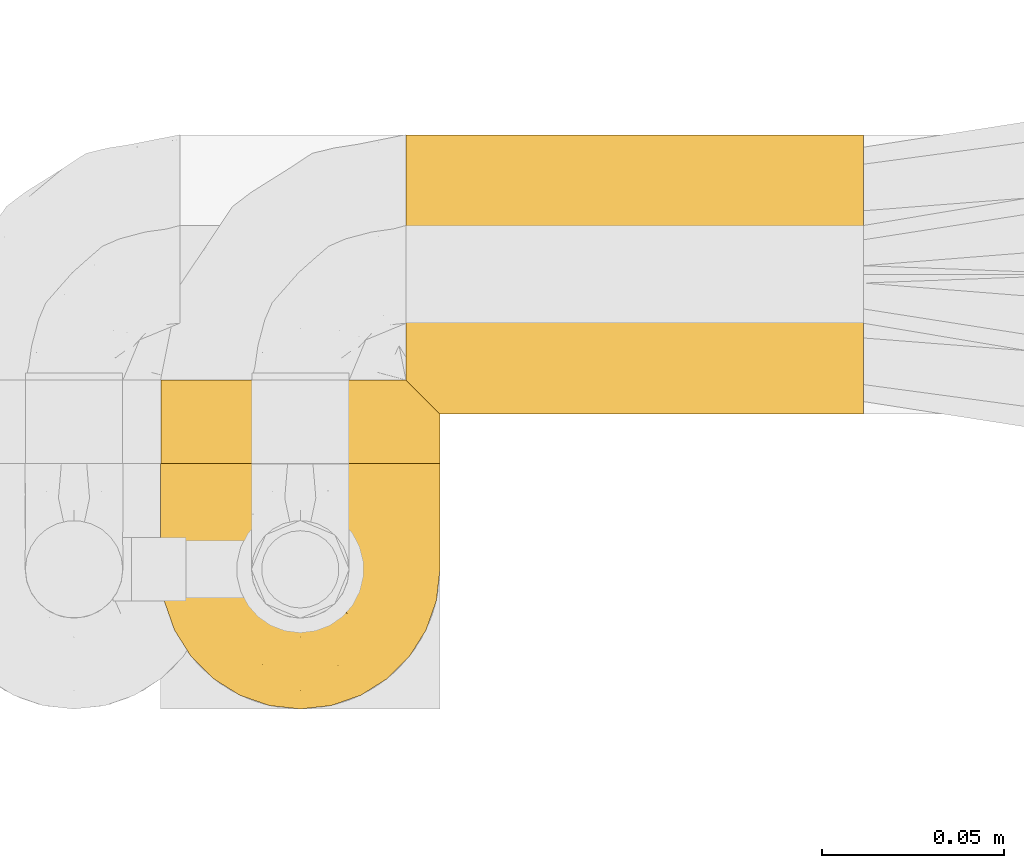
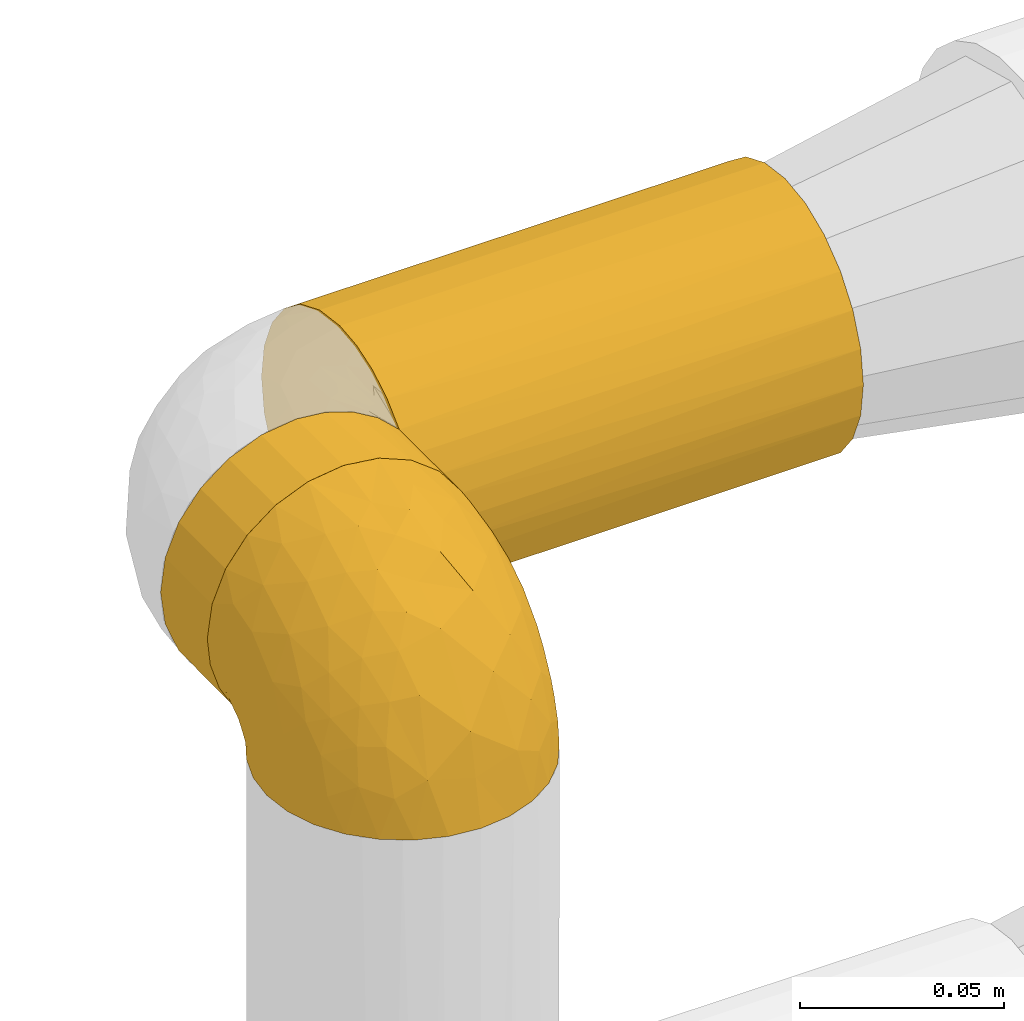
# One storey, part 335 of 827: 3 coverings.
"""IFC2X3 building model written with IfcOpenShell, lengths in millimetres."""

from ifc_helpers import new_model, entity, si_unit, converted_unit, derived_unit, direction, frame, origin, place, context, subcontext, project, spatial, faceted_brep, element, save


model = new_model("IFC2X3")

# Units and contexts
model_context = context("Model", 3, precision=0.01, world=origin(), true_north=direction((6.12303176911189e-17, 1.0)))
body_context = subcontext(model_context, "Body", "Model", "MODEL_VIEW")
ifc_project = project(units=[si_unit("LENGTHUNIT", "METRE", prefix="MILLI"), si_unit("AREAUNIT", "SQUARE_METRE"), si_unit("VOLUMEUNIT", "CUBIC_METRE"), converted_unit("PLANEANGLEUNIT", "DEGREE", entity("IfcRatioMeasure", 0.0174532925199433), si_unit("PLANEANGLEUNIT", "RADIAN"), dimensions=[0, 0, 0, 0, 0, 0, 0]), si_unit("MASSUNIT", "GRAM", prefix="KILO"), derived_unit("MASSDENSITYUNIT", [(si_unit("MASSUNIT", "GRAM", prefix="KILO"), 1), (si_unit("LENGTHUNIT", "METRE"), -3)]), derived_unit("MOMENTOFINERTIAUNIT", [(si_unit("LENGTHUNIT", "METRE"), 4)]), si_unit("TIMEUNIT", "SECOND"), si_unit("FREQUENCYUNIT", "HERTZ"), si_unit("THERMODYNAMICTEMPERATUREUNIT", "DEGREE_CELSIUS"), derived_unit("THERMALTRANSMITTANCEUNIT", [(si_unit("MASSUNIT", "GRAM", prefix="KILO"), 1), (si_unit("THERMODYNAMICTEMPERATUREUNIT", "KELVIN"), -1), (si_unit("TIMEUNIT", "SECOND"), -3)]), derived_unit("VOLUMETRICFLOWRATEUNIT", [(si_unit("LENGTHUNIT", "METRE"), 3), (si_unit("TIMEUNIT", "SECOND"), -1)]), derived_unit("MASSFLOWRATEUNIT", [(si_unit("MASSUNIT", "GRAM", prefix="KILO"), 1), (si_unit("TIMEUNIT", "SECOND"), -1)]), derived_unit("ROTATIONALFREQUENCYUNIT", [(si_unit("TIMEUNIT", "SECOND"), -1)]), si_unit("ELECTRICCURRENTUNIT", "AMPERE"), si_unit("ELECTRICVOLTAGEUNIT", "VOLT"), si_unit("POWERUNIT", "WATT"), si_unit("FORCEUNIT", "NEWTON", prefix="KILO"), si_unit("ILLUMINANCEUNIT", "LUX"), si_unit("LUMINOUSFLUXUNIT", "LUMEN"), si_unit("LUMINOUSINTENSITYUNIT", "CANDELA"), derived_unit("USERDEFINED", [(si_unit("MASSUNIT", "GRAM", prefix="KILO"), -1), (si_unit("LENGTHUNIT", "METRE"), -2), (si_unit("TIMEUNIT", "SECOND"), 3), (si_unit("LUMINOUSFLUXUNIT", "LUMEN"), 1)]), derived_unit("LINEARVELOCITYUNIT", [(si_unit("LENGTHUNIT", "METRE"), 1), (si_unit("TIMEUNIT", "SECOND"), -1)]), si_unit("PRESSUREUNIT", "PASCAL"), derived_unit("USERDEFINED", [(si_unit("LENGTHUNIT", "METRE"), -2), (si_unit("MASSUNIT", "GRAM", prefix="KILO"), 1), (si_unit("TIMEUNIT", "SECOND"), -2)]), derived_unit("LINEARFORCEUNIT", [(si_unit("MASSUNIT", "GRAM", prefix="KILO"), 1), (si_unit("LENGTHUNIT", "METRE"), 1), (si_unit("TIMEUNIT", "SECOND"), -2), (si_unit("LENGTHUNIT", "METRE"), -1)]), derived_unit("PLANARFORCEUNIT", [(si_unit("MASSUNIT", "GRAM", prefix="KILO"), 1), (si_unit("LENGTHUNIT", "METRE"), 1), (si_unit("TIMEUNIT", "SECOND"), -2), (si_unit("LENGTHUNIT", "METRE"), -2)])], contexts=[model_context])

# Site, building, storey
site_placement = place(None, origin())
site = spatial("IfcSite", under=ifc_project, at=site_placement, CompositionType="ELEMENT")
building_placement = place(site_placement, origin())
building = spatial("IfcBuilding", under=site, at=building_placement, CompositionType="ELEMENT")
storey_placement = place(building_placement, frame((0.0, 0.0, 28200.0)))
storey = spatial("IfcBuildingStorey", under=building, at=storey_placement, Name="08", CompositionType="ELEMENT", Elevation=28200.0)

# Coverings
covering_1_placement = place(storey_placement, frame((35083.54, 19454.61, 1910.0)))
element("IfcCovering", 1, at=covering_1_placement, inside=storey, Name=":ADSK_", ObjectType=":ADSK_", PredefinedType="INSULATION", context=body_context, shape_type="Brep", body=[
    faceted_brep([(1.6, 23.98, 5.09), (1.6, 16.91, 9.31), (1.6, 10.9, 14.94), (1.6, 10.9, 65.05), (1.6, 16.91, 70.68), (1.6, 23.98, 74.9), (1.6, 31.79, 77.51), (1.6, 40.0, 78.4), (1.6, 49.93, 77.09), (1.6, 59.2, 73.25), (1.6, 67.15, 67.15), (1.6, 73.25, 59.2), (1.6, 77.09, 49.93), (1.6, 78.4, 40.0), (1.6, 77.09, 30.06), (1.6, 73.25, 20.8), (1.6, 67.15, 12.84), (1.6, 59.2, 6.74), (1.6, 49.93, 2.9), (1.6, 40.0, 1.6), (1.6, 31.79, 2.48), (127.48, 1.6, 40.0), (127.48, 2.9, 30.06), (127.48, 6.74, 20.8), (127.48, 12.84, 12.84), (127.48, 20.8, 6.74), (127.48, 30.06, 2.9), (127.48, 40.0, 1.6), (127.48, 49.93, 2.9), (127.48, 59.2, 6.74), (127.48, 67.15, 12.84), (127.48, 73.25, 20.8), (127.48, 77.09, 30.06), (127.48, 78.4, 40.0), (127.48, 77.09, 49.93), (127.48, 73.25, 59.2), (127.48, 67.15, 67.15), (127.48, 59.2, 73.25), (127.48, 49.93, 77.09), (127.48, 40.0, 78.4), (127.48, 30.06, 77.09), (127.48, 20.8, 73.25), (127.48, 12.84, 67.15), (127.48, 6.74, 59.2), (127.48, 2.9, 49.93), (8.5, 4.0, 26.63), (10.29, 2.2, 33.21), (10.9, 1.6, 40.0), (5.57, 6.92, 20.48), (10.29, 2.2, 46.78), (8.5, 4.0, 53.36), (5.57, 6.92, 59.51)], [[[0, 1, 2, 3, 4, 5, 6, 7, 8, 9, 10, 11, 12, 13, 14, 15, 16, 17, 18, 19, 20]], [[21, 22, 23, 24, 25, 26, 27, 28, 29, 30, 31, 32, 33, 34, 35, 36, 37, 38, 39, 40, 41, 42, 43, 44]], [[32, 31, 15, 14]], [[33, 32, 14, 13]], [[31, 30, 16, 15]], [[18, 17, 29, 28]], [[19, 18, 28, 27]], [[30, 29, 17, 16]], [[20, 27, 26]], [[0, 26, 25]], [[1, 25, 24]], [[19, 27, 20]], [[20, 26, 0]], [[25, 1, 0]], [[24, 2, 1]], [[45, 23, 22]], [[22, 21, 46]], [[47, 46, 21]], [[48, 2, 23]], [[46, 45, 22]], [[48, 23, 45]], [[23, 2, 24]], [[49, 47, 21]], [[49, 21, 44]], [[50, 44, 43]], [[50, 49, 44]], [[3, 51, 43]], [[50, 43, 51]], [[43, 42, 3]], [[4, 42, 41]], [[5, 41, 40]], [[6, 40, 39]], [[4, 41, 5]], [[5, 40, 6]], [[39, 7, 6]], [[42, 4, 3]], [[8, 7, 39, 38]], [[9, 8, 38, 37]], [[37, 36, 10, 9]], [[12, 11, 35, 34]], [[13, 12, 34, 33]], [[36, 35, 11, 10]], [[2, 48, 45, 46, 47, 49, 50, 51, 3]]]),
])
covering_2_placement = place(storey_placement, frame((35016.04, 19440.94, 1910.0)))
element("IfcCovering", 2, at=covering_2_placement, inside=storey, Name=":ADSK_", ObjectType=":ADSK_", PredefinedType="INSULATION", context=body_context, shape_type="Brep", body=[
    faceted_brep([(20.8, 24.57, 73.25), (30.06, 24.57, 77.09), (40.0, 24.57, 78.4), (48.2, 24.57, 77.51), (56.01, 24.57, 74.9), (63.08, 24.57, 70.68), (69.1, 24.57, 65.05), (69.1, 24.57, 14.94), (63.08, 24.57, 9.31), (56.01, 24.57, 5.09), (48.2, 24.57, 2.48), (40.0, 24.57, 1.6), (30.06, 24.57, 2.9), (20.8, 24.57, 6.74), (12.84, 24.57, 12.84), (6.74, 24.57, 20.8), (2.9, 24.57, 30.06), (1.6, 24.57, 40.0), (2.9, 24.57, 49.93), (6.74, 24.57, 59.2), (12.84, 24.57, 67.15), (40.0, 1.6, 78.4), (30.06, 1.6, 77.09), (20.8, 1.6, 73.25), (12.84, 1.6, 67.15), (6.74, 1.6, 59.2), (2.9, 1.6, 49.93), (1.6, 1.6, 40.0), (2.48, 1.6, 31.79), (5.09, 1.6, 23.98), (9.31, 1.6, 16.91), (14.94, 1.6, 10.9), (65.05, 1.6, 10.9), (70.68, 1.6, 16.91), (74.9, 1.6, 23.98), (77.51, 1.6, 31.79), (78.4, 1.6, 40.0), (77.09, 1.6, 49.93), (73.25, 1.6, 59.2), (67.15, 1.6, 67.15), (59.2, 1.6, 73.25), (49.93, 1.6, 77.09), (77.79, 15.87, 33.21), (76.0, 17.67, 26.63), (73.07, 20.6, 20.48), (78.4, 15.27, 40.0), (59.51, 5.57, 6.92), (53.36, 8.5, 4.0), (46.78, 10.29, 2.2), (40.0, 10.9, 1.6), (33.21, 10.29, 2.2), (26.63, 8.5, 4.0), (20.48, 5.57, 6.92), (76.0, 17.67, 53.36), (77.79, 15.87, 46.78), (73.07, 20.6, 59.51)], [[[0, 1, 2, 3, 4, 5, 6, 7, 8, 9, 10, 11, 12, 13, 14, 15, 16, 17, 18, 19, 20]], [[21, 22, 23, 24, 25, 26, 27, 28, 29, 30, 31, 32, 33, 34, 35, 36, 37, 38, 39, 40, 41]], [[42, 36, 35]], [[35, 34, 43]], [[33, 44, 34]], [[42, 45, 36]], [[44, 43, 34]], [[7, 44, 33]], [[42, 35, 43]], [[33, 32, 7]], [[32, 46, 8]], [[47, 48, 10]], [[46, 47, 9]], [[8, 46, 9]], [[48, 11, 10]], [[10, 9, 47]], [[11, 48, 49]], [[32, 8, 7]], [[50, 51, 12]], [[13, 52, 14]], [[51, 52, 13]], [[49, 50, 11]], [[11, 50, 12]], [[51, 13, 12]], [[52, 31, 14]], [[15, 30, 29]], [[29, 28, 16]], [[27, 17, 28]], [[14, 30, 15]], [[16, 15, 29]], [[17, 16, 28]], [[30, 14, 31]], [[17, 27, 26, 18]], [[18, 26, 25, 19]], [[19, 25, 24, 20]], [[0, 23, 22, 1]], [[1, 22, 21, 2]], [[20, 24, 23, 0]], [[3, 21, 41]], [[41, 40, 4]], [[39, 5, 40]], [[2, 21, 3]], [[4, 3, 41]], [[5, 4, 40]], [[39, 6, 5]], [[53, 38, 37]], [[37, 36, 54]], [[45, 54, 36]], [[6, 39, 55]], [[54, 53, 37]], [[55, 38, 53]], [[55, 39, 38]], [[6, 55, 53, 54, 45, 42, 43, 44, 7]], [[52, 51, 50, 49, 48, 47, 46, 32, 31]]]),
])
covering_3_placement = place(storey_placement, frame((35015.99, 19373.39, 1919.3)))
element("IfcCovering", 3, at=covering_3_placement, inside=storey, Name=":ADSK_", ObjectType=":ADSK_", PredefinedType="INSULATION", context=body_context, shape_type="Brep", body=[
    faceted_brep([(74.68, 23.36, 1.6), (70.1, 16.07, 1.6), (64.01, 9.98, 1.6), (56.72, 5.4, 1.6), (48.6, 2.56, 1.6), (40.05, 1.6, 1.6), (31.49, 2.56, 1.6), (23.36, 5.41, 1.6), (16.07, 9.99, 1.6), (9.98, 16.08, 1.6), (5.4, 23.37, 1.6), (2.56, 31.49, 1.6), (1.6, 40.05, 1.6), (2.46, 48.15, 1.6), (5.01, 55.88, 1.6), (9.13, 62.9, 1.6), (14.62, 68.89, 1.6), (16.82, 68.89, 1.6), (18.56, 68.89, 1.6), (20.52, 68.89, 1.6), (22.49, 68.89, 1.6), (24.46, 68.89, 1.6), (26.42, 68.89, 1.6), (28.39, 68.89, 1.6), (30.36, 68.89, 1.6), (32.55, 68.89, 1.6), (34.75, 68.89, 1.6), (36.94, 68.89, 1.6), (39.13, 68.89, 1.6), (41.33, 68.89, 1.6), (43.52, 68.89, 1.6), (45.72, 68.89, 1.6), (47.91, 68.89, 1.6), (50.11, 68.89, 1.6), (52.3, 68.89, 1.6), (54.49, 68.89, 1.6), (56.69, 68.89, 1.6), (58.88, 68.89, 1.6), (61.08, 68.89, 1.6), (63.27, 68.89, 1.6), (65.47, 68.89, 1.6), (70.97, 62.89, 1.6), (75.09, 55.86, 1.6), (77.64, 48.13, 1.6), (78.5, 40.05, 1.6), (77.53, 31.49, 1.6), (14.62, 69.15, 1.85), (9.12, 69.15, 7.85), (5.0, 69.15, 14.87), (2.46, 69.15, 22.6), (1.6, 69.15, 30.7), (2.91, 69.15, 40.65), (6.75, 69.15, 49.92), (12.86, 69.15, 57.88), (20.82, 69.15, 63.99), (30.09, 69.15, 67.84), (40.05, 69.15, 69.15), (50.0, 69.15, 67.84), (59.27, 69.15, 63.99), (67.23, 69.15, 57.88), (73.34, 69.15, 49.92), (77.19, 69.15, 40.65), (78.5, 69.15, 30.7), (77.63, 69.15, 22.6), (75.09, 69.15, 14.87), (70.97, 69.15, 7.85), (65.47, 69.15, 1.85), (63.27, 69.15, 1.85), (62.29, 69.15, 1.85), (60.7, 69.15, 1.85), (59.11, 69.15, 1.85), (57.52, 69.15, 1.85), (55.93, 69.15, 1.85), (54.34, 69.15, 1.85), (52.76, 69.15, 1.85), (51.17, 69.15, 1.85), (49.58, 69.15, 1.85), (47.99, 69.15, 1.85), (46.4, 69.15, 1.85), (44.81, 69.15, 1.85), (43.22, 69.15, 1.85), (41.63, 69.15, 1.85), (40.05, 69.15, 1.85), (38.46, 69.15, 1.85), (36.87, 69.15, 1.85), (35.28, 69.15, 1.85), (33.69, 69.15, 1.85), (32.1, 69.15, 1.85), (30.51, 69.15, 1.85), (28.92, 69.15, 1.85), (27.33, 69.15, 1.85), (25.37, 69.15, 1.85), (23.4, 69.15, 1.85), (21.21, 69.15, 1.85), (19.01, 69.15, 1.85), (16.82, 69.15, 1.85), (42.32, 68.96, 1.77), (44.02, 68.97, 1.78), (47.13, 68.97, 1.77), (48.74, 68.97, 1.77), (23.57, 68.95, 1.76), (25.13, 68.96, 1.77), (61.34, 68.98, 1.79), (22.02, 68.97, 1.78), (29.72, 68.97, 1.78), (56.73, 68.98, 1.78), (55.14, 68.97, 1.78), (37.66, 68.97, 1.78), (64.12, 68.94, 1.74), (28.13, 68.98, 1.78), (26.62, 68.98, 1.78), (31.46, 68.96, 1.77), (16.16, 68.97, 1.78), (39.16, 68.98, 1.78), (50.37, 68.98, 1.78), (17.69, 68.97, 1.77), (19.17, 68.96, 1.77), (62.78, 68.97, 1.77), (58.35, 68.97, 1.78), (45.53, 68.98, 1.78), (59.91, 68.96, 1.77), (65.47, 68.97, 1.77), (65.47, 68.94, 1.72), (65.47, 68.92, 1.66), (14.62, 68.97, 1.77), (14.62, 69.02, 1.8), (14.62, 69.08, 1.82), (20.59, 68.98, 1.79), (32.99, 68.97, 1.78), (34.48, 68.98, 1.79), (51.91, 68.97, 1.78), (65.47, 69.08, 1.82), (65.47, 69.02, 1.8), (53.48, 68.96, 1.76), (14.62, 68.92, 1.66), (14.62, 68.94, 1.72), (40.77, 68.97, 1.78), (35.97, 68.96, 1.77), (7.84, 67.02, 9.41), (3.53, 63.33, 17.65), (8.32, 64.61, 7.41), (1.6, 49.27, 21.47), (2.19, 51.4, 15.21), (1.6, 43.94, 16.15), (1.6, 61.87, 28.75), (4.57, 61.54, 13.67), (3.96, 57.95, 12.79), (2.28, 56.12, 19.18), (1.6, 63.4, 29.16), (7.69, 65.41, 9.04), (3.53, 53.1, 7.41), (8.32, 63.04, 5.74), (7.84, 61.33, 3.72), (1.6, 41.99, 8.87), (1.6, 54.6, 26.8), (4.34, 56.6, 9.53), (1.6, 41.58, 7.34), (29.63, 13.72, 37.63), (27.34, 5.82, 17.92), (40.05, 6.74, 27.45), (2.39, 58.82, 37.01), (2.43, 51.58, 34.22), (9.07, 42.09, 45.87), (16.64, 46.12, 56.57), (9.54, 55.56, 52.31), (4.52, 52.38, 42.07), (4.52, 61.54, 44.74), (7.49, 23.76, 21.49), (7.49, 20.5, 11.02), (12.85, 14.64, 15.64), (2.35, 41.77, 26.02), (22.66, 16.28, 36.59), (32.9, 49.4, 65.49), (25.33, 52.34, 63.99), (40.05, 4.3, 15.2), (16.64, 58.67, 60.27), (19.99, 25.26, 45.25), (16.37, 20.17, 35.21), (3.26, 34.7, 22.52), (3.75, 28.67, 12.03), (19.58, 8.62, 13.32), (7.5, 33.37, 35.9), (4.04, 41.35, 33.87), (13.94, 17.15, 25.73), (19.58, 12.68, 26.34), (28.21, 21.47, 46.78), (24.75, 41.11, 59.54), (31.42, 37.53, 60.18), (26.2, 30.64, 53.93), (33.36, 26.66, 53.36), (40.05, 21.38, 49.36), (40.05, 14.06, 38.4), (40.05, 55.54, 66.44), (16.14, 35.17, 50.09), (12.85, 29.04, 41.08), (10.47, 24.34, 31.14), (6.49, 29.33, 28.19), (40.05, 43.3, 64.0), (40.05, 32.34, 56.68), (75.57, 57.75, 43.9), (47.37, 49.41, 65.46), (52.91, 27.85, 52.22), (50.46, 13.7, 37.61), (67.23, 14.63, 15.64), (60.5, 8.61, 13.31), (70.55, 48.85, 50.02), (63.45, 54.13, 59.28), (62.61, 37.84, 53.05), (72.6, 23.75, 21.48), (72.6, 20.49, 11.01), (76.34, 28.66, 12.03), (59.34, 20.83, 41.02), (77.76, 55.15, 35.39), (78.5, 54.6, 26.8), (78.5, 61.87, 28.75), (78.5, 41.58, 7.34), (53.16, 57.58, 65.81), (70.55, 59.91, 53.28), (48.88, 36.94, 59.8), (54.76, 45.72, 61.82), (52.74, 5.82, 17.91), (71.93, 37.91, 41.4), (75.79, 50.18, 40.48), (60.5, 12.67, 26.34), (77.86, 49.29, 31.68), (77.64, 42.64, 27.68), (78.5, 43.94, 16.15), (78.5, 49.27, 21.47), (67.23, 19.45, 28.05), (76.82, 34.7, 22.54), (78.5, 41.99, 8.87), (77.8, 62.29, 37.3), (67.23, 29.01, 41.07), (73.2, 31.47, 32.24), (67.66, 37.18, 47.4), (75.99, 43.45, 35.77), (76.57, 63.33, 17.65), (73.21, 67.23, 11.06), (71.93, 66.07, 8.55), (71.07, 65.22, 6.63), (75.09, 61.99, 12.77), (76.13, 57.95, 12.79), (76.57, 53.09, 7.41), (77.69, 56.84, 18.97), (72.26, 61.33, 3.72), (71.77, 63.06, 5.76), (77.9, 51.41, 15.21), (75.75, 56.61, 9.52)], [[[0, 1, 2, 3, 4, 5, 6, 7, 8, 9, 10, 11, 12, 13, 14, 15, 16, 17, 18, 19, 20, 21, 22, 23, 24, 25, 26, 27, 28, 29, 30, 31, 32, 33, 34, 35, 36, 37, 38, 39, 40, 41, 42, 43, 44, 45]], [[46, 47, 48, 49, 50, 51, 52, 53, 54, 55, 56, 57, 58, 59, 60, 61, 62, 63, 64, 65, 66, 67, 68, 69, 70, 71, 72, 73, 74, 75, 76, 77, 78, 79, 80, 81, 82, 83, 84, 85, 86, 87, 88, 89, 90, 91, 92, 93, 94, 95]], [[96, 97, 30]], [[98, 77, 99]], [[100, 101, 21]], [[69, 68, 102]], [[20, 19, 103]], [[24, 23, 104]], [[20, 103, 100]], [[72, 105, 106]], [[84, 83, 107]], [[89, 88, 104]], [[108, 67, 66]], [[109, 110, 90]], [[111, 25, 24]], [[112, 17, 16]], [[82, 113, 83]], [[109, 23, 22]], [[114, 76, 75]], [[105, 36, 106]], [[104, 111, 24]], [[18, 115, 116]], [[97, 96, 80]], [[67, 108, 117]], [[105, 71, 118]], [[31, 97, 119]], [[102, 120, 69]], [[108, 121, 122, 123, 40]], [[112, 95, 115]], [[17, 115, 18]], [[94, 116, 115]], [[117, 68, 67]], [[38, 117, 39]], [[112, 124, 125, 126, 46]], [[17, 112, 115]], [[70, 120, 118]], [[39, 117, 108]], [[120, 38, 37]], [[120, 37, 118]], [[120, 70, 69]], [[116, 94, 127]], [[128, 86, 129]], [[117, 38, 102]], [[74, 130, 75]], [[99, 33, 32]], [[115, 95, 94]], [[39, 108, 40]], [[108, 66, 131, 132, 121]], [[105, 72, 71]], [[118, 37, 36]], [[71, 70, 118]], [[35, 106, 36]], [[36, 105, 118]], [[35, 133, 106]], [[74, 73, 133]], [[106, 133, 73]], [[99, 114, 33]], [[133, 35, 34]], [[73, 72, 106]], [[95, 112, 46]], [[112, 16, 134, 135, 124]], [[130, 114, 75]], [[99, 76, 114]], [[114, 130, 33]], [[34, 33, 130]], [[78, 77, 98]], [[98, 119, 78]], [[130, 133, 34]], [[133, 130, 74]], [[79, 97, 80]], [[98, 99, 32]], [[98, 32, 31]], [[77, 76, 99]], [[97, 79, 119]], [[136, 96, 29]], [[30, 97, 31]], [[136, 29, 28]], [[81, 80, 96]], [[29, 96, 30]], [[31, 119, 98]], [[119, 79, 78]], [[96, 136, 81]], [[82, 81, 136]], [[113, 107, 83]], [[84, 107, 137]], [[107, 27, 137]], [[113, 28, 107]], [[27, 107, 28]], [[85, 84, 137]], [[137, 27, 26]], [[113, 136, 28]], [[136, 113, 82]], [[109, 89, 104]], [[86, 85, 129]], [[89, 109, 90]], [[111, 87, 128]], [[26, 129, 137]], [[88, 111, 104]], [[25, 111, 128]], [[22, 110, 109]], [[23, 109, 104]], [[110, 91, 90]], [[100, 92, 101]], [[110, 22, 101]], [[91, 110, 101]], [[116, 19, 18]], [[111, 88, 87]], [[127, 103, 19]], [[25, 128, 26]], [[86, 128, 87]], [[128, 129, 26]], [[137, 129, 85]], [[120, 102, 38]], [[117, 102, 68]], [[91, 101, 92]], [[21, 101, 22]], [[93, 92, 103]], [[100, 21, 20]], [[100, 103, 92]], [[127, 93, 103]], [[93, 127, 94]], [[116, 127, 19]], [[126, 138, 47]], [[48, 138, 139]], [[140, 125, 124]], [[141, 142, 143]], [[144, 49, 139]], [[145, 140, 146]], [[48, 139, 49]], [[139, 145, 147]], [[49, 144, 148, 50]], [[126, 125, 149]], [[14, 13, 150]], [[151, 146, 140]], [[149, 140, 145]], [[152, 151, 135]], [[152, 14, 150]], [[16, 15, 134]], [[13, 153, 150]], [[124, 151, 140]], [[141, 147, 142]], [[14, 152, 15]], [[15, 152, 134]], [[47, 46, 126]], [[139, 154, 144]], [[138, 48, 47]], [[125, 140, 149]], [[135, 134, 152]], [[146, 155, 142]], [[145, 146, 147]], [[149, 139, 138]], [[147, 141, 154]], [[147, 146, 142]], [[139, 147, 154]], [[139, 149, 145]], [[149, 138, 126]], [[155, 146, 151]], [[150, 143, 142]], [[152, 155, 151]], [[150, 142, 155]], [[13, 12, 156, 153]], [[153, 143, 150]], [[152, 150, 155]], [[151, 124, 135]], [[157, 158, 159]], [[160, 154, 161]], [[162, 163, 164]], [[165, 166, 160]], [[167, 168, 169]], [[141, 170, 161]], [[156, 12, 11]], [[158, 157, 171]], [[172, 55, 173]], [[158, 6, 174]], [[175, 54, 53]], [[52, 166, 164]], [[52, 164, 53]], [[54, 175, 173]], [[166, 52, 51]], [[176, 177, 171]], [[178, 143, 179]], [[156, 11, 179]], [[8, 7, 180]], [[169, 9, 8]], [[179, 143, 153, 156]], [[179, 11, 10]], [[168, 179, 10]], [[181, 162, 182]], [[179, 167, 178]], [[183, 184, 177]], [[183, 169, 184]], [[176, 171, 185]], [[172, 186, 187]], [[158, 7, 6]], [[159, 158, 174]], [[184, 180, 158]], [[54, 173, 55]], [[180, 169, 8]], [[188, 189, 187]], [[9, 168, 10]], [[186, 188, 187]], [[190, 157, 159, 191]], [[55, 172, 192]], [[176, 193, 194]], [[161, 170, 182]], [[162, 164, 165]], [[175, 164, 163]], [[51, 50, 148]], [[167, 195, 196]], [[178, 182, 170]], [[6, 5, 174]], [[158, 180, 7]], [[169, 180, 184]], [[169, 168, 9]], [[179, 168, 167]], [[182, 162, 165]], [[162, 194, 193]], [[161, 165, 160]], [[195, 181, 196]], [[192, 172, 197]], [[192, 56, 55]], [[189, 190, 198]], [[198, 197, 187]], [[172, 187, 197]], [[185, 189, 188]], [[198, 187, 189]], [[186, 172, 173]], [[173, 163, 186]], [[193, 186, 163]], [[176, 185, 188]], [[185, 157, 190]], [[188, 186, 193]], [[177, 176, 194]], [[188, 193, 176]], [[162, 193, 163]], [[195, 177, 194]], [[171, 177, 184]], [[181, 195, 194]], [[183, 167, 169]], [[162, 181, 194]], [[196, 182, 178]], [[158, 171, 184]], [[171, 157, 185]], [[177, 195, 183]], [[167, 183, 195]], [[182, 196, 181]], [[178, 170, 143]], [[178, 167, 196]], [[164, 175, 53]], [[173, 175, 163]], [[160, 51, 148]], [[164, 166, 165]], [[51, 160, 166]], [[160, 148, 144, 154]], [[141, 161, 154]], [[182, 165, 161]], [[190, 189, 185]], [[143, 170, 141]], [[60, 199, 61]], [[197, 200, 192]], [[201, 190, 202]], [[200, 57, 192]], [[203, 204, 2]], [[205, 206, 207]], [[208, 209, 210]], [[211, 207, 201]], [[212, 213, 214]], [[45, 215, 210]], [[216, 206, 58]], [[45, 44, 215]], [[59, 217, 60]], [[60, 217, 199]], [[0, 45, 210]], [[218, 201, 219]], [[202, 159, 220]], [[205, 221, 222]], [[223, 204, 203]], [[1, 203, 2]], [[57, 200, 216]], [[220, 3, 204]], [[220, 174, 4]], [[1, 0, 209]], [[212, 224, 213]], [[225, 226, 227]], [[228, 223, 203]], [[208, 210, 229]], [[210, 226, 229]], [[3, 220, 4]], [[58, 206, 59]], [[209, 203, 1]], [[202, 220, 223]], [[228, 203, 208]], [[202, 211, 201]], [[3, 2, 204]], [[202, 190, 191, 159]], [[210, 215, 230, 226]], [[199, 212, 231]], [[232, 233, 221]], [[233, 208, 229]], [[207, 206, 219]], [[217, 206, 205]], [[227, 224, 225]], [[233, 232, 228]], [[201, 207, 219]], [[234, 232, 221]], [[218, 219, 200]], [[202, 223, 211]], [[174, 220, 159]], [[174, 5, 4]], [[61, 231, 62]], [[220, 204, 223]], [[210, 209, 0]], [[203, 209, 208]], [[225, 233, 229]], [[224, 227, 213]], [[221, 233, 235]], [[57, 56, 192]], [[198, 218, 197]], [[200, 219, 216]], [[201, 198, 190]], [[197, 218, 200]], [[198, 201, 218]], [[206, 216, 219]], [[58, 57, 216]], [[231, 212, 214]], [[222, 212, 199]], [[228, 211, 223]], [[207, 211, 232]], [[62, 231, 214]], [[199, 231, 61]], [[233, 228, 208]], [[211, 228, 232]], [[222, 221, 235]], [[234, 205, 207]], [[206, 217, 59]], [[199, 217, 205]], [[205, 222, 199]], [[224, 222, 235]], [[222, 224, 212]], [[224, 235, 225]], [[233, 225, 235]], [[226, 225, 229]], [[205, 234, 221]], [[207, 232, 234]], [[63, 214, 236]], [[214, 213, 236]], [[214, 63, 62]], [[237, 236, 238]], [[238, 132, 131]], [[236, 237, 64]], [[239, 240, 241]], [[63, 236, 64]], [[131, 66, 65]], [[237, 131, 65]], [[242, 230, 43]], [[237, 65, 64]], [[239, 121, 132]], [[42, 242, 43]], [[241, 240, 243]], [[41, 123, 244]], [[43, 230, 215, 44]], [[244, 122, 245]], [[227, 246, 243]], [[241, 247, 245]], [[121, 239, 245]], [[41, 40, 123]], [[132, 238, 239]], [[244, 42, 41]], [[131, 237, 238]], [[240, 239, 238]], [[245, 239, 241]], [[247, 241, 246]], [[247, 244, 245]], [[238, 236, 240]], [[243, 236, 213]], [[236, 243, 240]], [[227, 226, 246]], [[243, 213, 227]], [[242, 246, 226]], [[243, 246, 241]], [[246, 242, 247]], [[244, 247, 242]], [[242, 226, 230]], [[42, 244, 242]], [[122, 244, 123]], [[122, 121, 245]]]),
])

save(model, "model.ifc")
